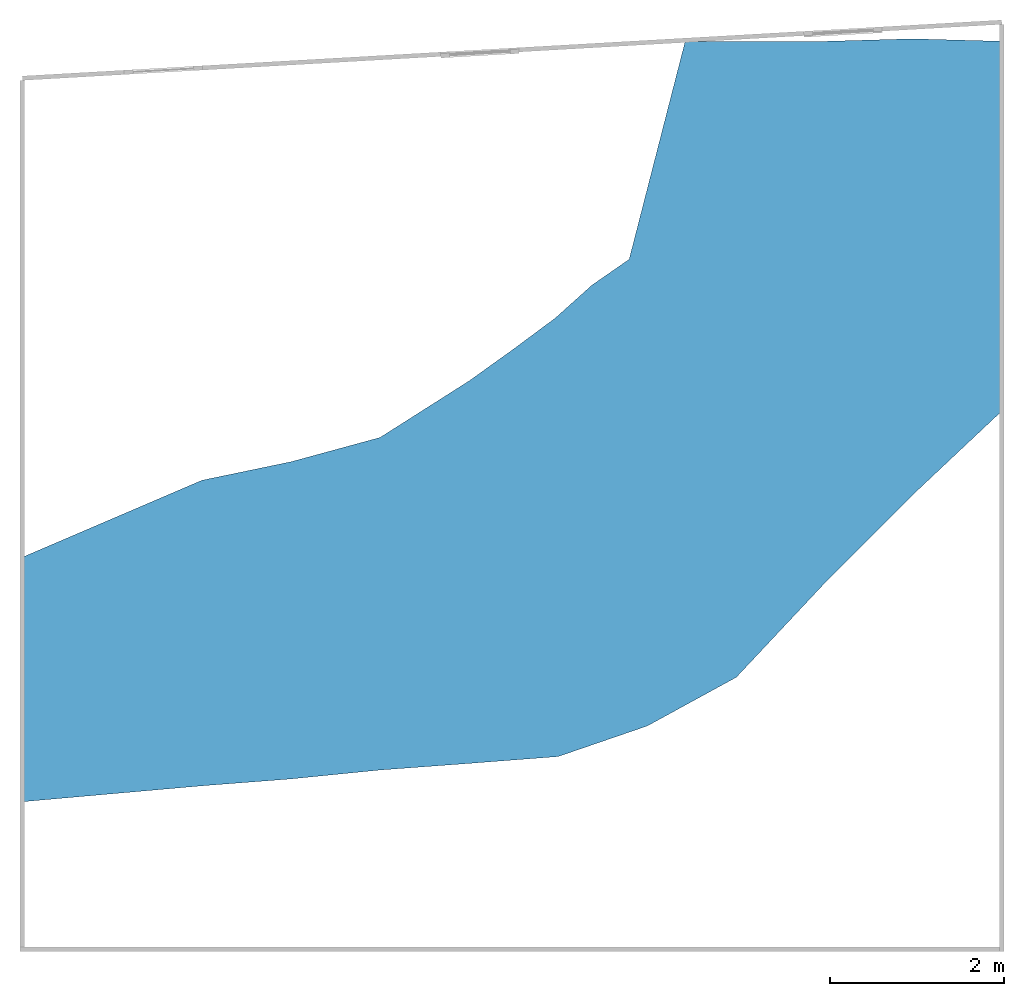
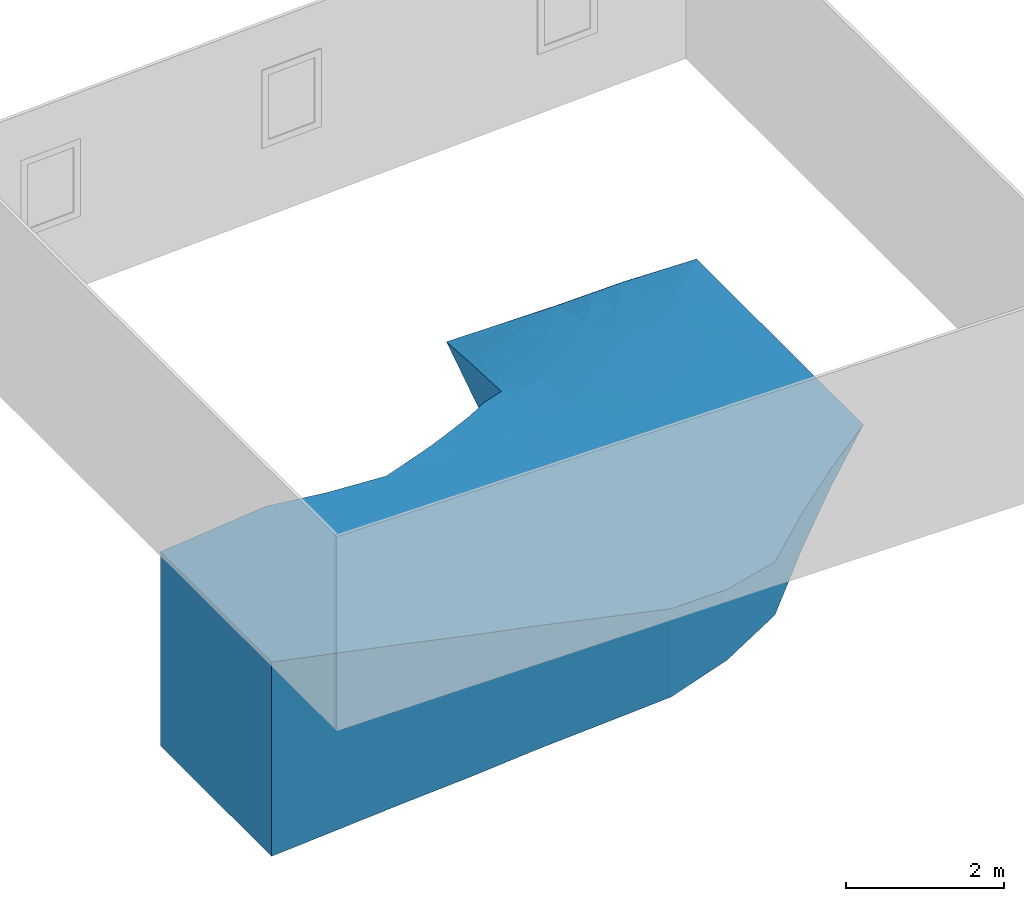
# One storey, part 2 of 3: 1 ramp.
"""IFC4 building model written with IfcOpenShell, lengths in metres."""

from ifc_helpers import new_model, entity, si_unit, converted_unit, frame, origin_with_axes, origin_2d_with_axis, place, context, subcontext, project, spatial, polygons, element, save


model = new_model("IFC4")

# Units and contexts
model_context = context("Model", 3, precision=1e-05, world=origin_with_axes())
plan_context = context("Plan", 2, precision=1e-05, world=origin_2d_with_axis())
body_context = subcontext(model_context, "Body", "Model", "MODEL_VIEW")
ifc_project = project(units=[si_unit("VOLUMEUNIT", "CUBIC_METRE"), si_unit("LENGTHUNIT", "METRE"), converted_unit("PLANEANGLEUNIT", "degree", entity("IfcReal", 0.0174532925199433), si_unit("PLANEANGLEUNIT", "RADIAN"), dimensions=[0, 0, 0, 0, 0, 0, 0]), si_unit("AREAUNIT", "SQUARE_METRE")], contexts=[model_context, plan_context])

# Site, building, storey
site_placement = place(None, origin_with_axes())
site = spatial("IfcSite", under=ifc_project, at=site_placement)
building_placement = place(site_placement, origin_with_axes())
building = spatial("IfcBuilding", under=site, at=building_placement, Name="Building")
storey_placement = place(building_placement, origin_with_axes())
storey = spatial("IfcBuildingStorey", under=building, at=storey_placement, Name="Storey0")

# Ramp
ramp_placement = place(storey_placement, frame((-2.38636875152588, -26.9014205932617, 3.0), z_axis=(0.0, 0.0, 1.0), x_axis=(1.0, 0.0, 0.0)))
element("IfcRamp", 1, at=ramp_placement, inside=storey, Name="Plane", PredefinedType="STRAIGHT_RUN_RAMP", context=body_context, shape_type="Tessellation", body=[
    polygons([(-1.00000011920929, -1.00000011920929, 0.0), (-1.00000011920929, 1.80932641029358, 0.0), (10.238823890686, 7.72010040283203, -3.0), (0.0217113513499498, -0.909389615058899, -0.272727310657501), (1.04342269897461, -0.818777203559875, -0.545454621315002), (2.06513404846191, -0.739626109600067, -0.818181991577148), (3.08684539794922, -0.637556254863739, -1.09090924263), (4.10855674743652, -0.561822950839996, -1.36363649368286), (5.13026809692383, -0.483061134815216, -1.63636386394501), (6.15197992324829, -0.13229013979435, -1.90909111499786), (7.1736912727356, 0.4265256524086, -2.18181848526001), (8.19540214538574, 1.51551151275635, -2.45454573631287), (9.21711349487305, 2.53799510002136, -2.72727298736572), (9.18832874298096, 7.74888467788696, -3.00458192825317), (8.19540119171143, 7.72010040283203, -3.00458192825317), (7.17369079589844, 7.72010135650635, -3.00000023841858), (6.58654451370239, 7.72010040283203, -3.0), (5.09745216369629, 4.54690027236938, -1.69928789138794), (4.10855627059937, 3.82565927505493, -1.3805969953537), (3.08684492111206, 3.17677140235901, -1.09090936183929), (2.06513357162476, 2.8982298374176, -0.818182051181793), (1.04342234134674, 2.68570160865784, -0.545454680919647), (0.0217111129313707, 2.24751305580139, -0.272727340459824), (-1.00000011920929, 0.842850804328918, 0.0), (10.2388248443604, 7.12004566192627, -3.00000023841858), (0.0217112321406603, 1.13569843769073, -0.272727340459824), (1.04342257976532, 1.42854702472687, -0.545454680919647), (2.06513381004333, 1.92072582244873, -0.818181991577148), (3.06936955451965, 2.31345629692078, -1.09094202518463), (3.9922149181366, 2.8869469165802, -1.36587369441986), (5.07592391967773, 3.56458282470703, -1.67543172836304), (6.07935428619385, 4.50835800170898, -2.01254725456238), (7.16741132736206, 5.27234745025635, -2.34002208709717), (8.32406616210938, 6.29180955886841, -2.69019794464111), (9.32558631896973, 6.72331237792969, -2.8524489402771), (5.94412326812744, 5.22002935409546, -2.02513146400452), (7.20553493499756, 6.58756732940674, -2.61047077178955), (6.47213459014893, 6.00016975402832, -2.36925721168518), (-1.00000011920929, -0.0785746648907661, 0.0), (10.2388248443604, 5.74165201187134, -3.00000023841858), (0.0217112917453051, 0.113154426217079, -0.272727340459824), (1.04342257976532, 0.304884940385818, -0.545454680919647), (2.06513381004333, 0.590549886226654, -0.818181991577148), (3.06989908218384, 0.895808279514313, -1.09032964706421), (4.02845764160156, 1.23502886295319, -1.36156272888184), (5.09470367431641, 1.70661246776581, -1.64855790138245), (6.09229803085327, 2.29203009605408, -1.92897129058838), (7.17361640930176, 3.00976157188416, -2.18193054199219), (8.20555305480957, 3.90138292312622, -2.48450517654419), (9.22030258178711, 4.76470804214478, -2.7475733757019), (-1.00000011920929, -0.539287388324738, 0.0), (9.7279691696167, 3.01871919631958, -2.86363673210144), (-0.489144504070282, 2.02841973304749, -0.136363670229912), (-0.489144384860992, -0.954694867134094, -0.136363655328751), (0.532567024230957, -0.864083409309387, -0.409090965986252), (1.55427837371826, -0.779201626777649, -0.681818306446075), (2.57598972320557, -0.688591182231903, -0.954545617103577), (3.59770107269287, -0.599689602851868, -1.22727286815643), (4.61941242218018, -0.522442042827606, -1.50000023841858), (5.64112377166748, -0.307675629854202, -1.77272748947144), (6.66283559799194, 0.147117763757706, -2.04545474052429), (7.68454647064209, 0.971018552780151, -2.31818199157715), (8.70625782012939, 2.02675342559814, -2.59090948104858), (9.7135763168335, 7.73449230194092, -3.00229096412659), (8.69186496734619, 7.73449230194092, -3.00458192825317), (7.68454551696777, 7.72010040283203, -3.00229096412659), (5.51701736450195, 4.92389678955078, -1.86913824081421), (4.61941194534302, 4.19182968139648, -1.54098784923553), (3.59770059585571, 3.50121545791626, -1.2357531785965), (2.57598924636841, 3.03750061988831, -0.954545736312866), (1.5542778968811, 2.79196572303772, -0.68181836605072), (0.532566726207733, 2.46660733222961, -0.409090995788574), (0.0217111725360155, 1.69160580635071, -0.272727340459824), (1.04342246055603, 2.057124376297, -0.545454680919647), (2.06513357162476, 2.40947771072388, -0.818181991577148), (3.08059000968933, 2.81641149520874, -1.09102737903595), (4.00673770904541, 3.41367888450623, -1.36823689937592), (5.07591152191162, 4.12479496002197, -1.68697142601013), (6.52955055236816, 6.70842695236206, -2.60109519958496), (7.18332719802856, 7.13279390335083, -2.79062366485596), (9.72796821594238, 7.21484136581421, -2.91390132904053), (-1.00000011920929, 1.32608866691589, 0.0), (9.20272064208984, 7.22923374176025, -2.91619253158569), (0.0217112619429827, 0.624426424503326, -0.272727340459824), (1.04342257976532, 0.866715967655182, -0.545454680919647), (2.06513381004333, 1.25563788414001, -0.818181991577148), (3.06653690338135, 1.64234089851379, -1.09049355983734), (4.01179122924805, 2.11637783050537, -1.36441612243652), (5.08355093002319, 2.71264362335205, -1.66118252277374), (6.07878303527832, 3.47108030319214, -1.95871615409851), (7.16494846343994, 4.20266771316528, -2.25952100753784), (8.2425651550293, 5.05424499511719, -2.5654308795929), (9.218186378479, 5.7711238861084, -2.77771949768066), (8.80649471282959, 6.38499975204468, -2.75708603858948), (7.71658420562744, 5.65891599655151, -2.51701068878174), (6.6453104019165, 4.81480836868286, -2.1861252784729), (5.56711530685425, 3.97225093841553, -1.83170568943024), (4.54249668121338, 3.15800905227661, -1.52025723457336), (3.53398513793945, 2.58593916893005, -1.2272881269455), (2.57598948478699, 2.18031215667725, -0.954545676708221), (1.55427813529968, 1.67463636398315, -0.68181836605072), (0.532566905021667, 1.2821227312088, -0.409090995788574), (-0.489144444465637, 0.989274621009827, -0.136363670229912), (9.7279691696167, 6.91481399536133, -2.91390156745911), (8.17750930786133, 6.96538877487183, -2.79819011688232), (5.92130422592163, 4.90296125411987, -1.99645256996155), (7.1907844543457, 5.97661972045898, -2.44536972045898), (6.2653341293335, 6.47006511688232, -2.50445795059204), (10.238823890686, 7.42007255554199, -3.0), (8.72216892242432, 7.12264156341553, -2.84850287437439), (6.34618759155273, 5.29341888427734, -2.16697382926941), (6.81265878677368, 6.26584243774414, -2.48552489280701), (-1.00000011920929, 0.382138073444366, 0.0), (10.2388248443604, 4.6205472946167, -3.00000023841858), (0.0217113215476274, -0.39811760187149, -0.272727310657501), (1.04342269897461, -0.25694614648819, -0.545454621315002), (2.06513404846191, -0.0745381116867065, -0.818181991577148), (3.08684539794922, 0.13180735707283, -1.09090924263), (4.05365180969238, 0.326851159334183, -1.36086797714233), (5.13026809692383, 0.627216935157776, -1.64246964454651), (6.0985221862793, 1.06404888629913, -1.91749453544617), (7.17369079589844, 1.7180243730545, -2.18181848526001), (8.19540214538574, 2.70086908340454, -2.45454573631287), (9.21711349487305, 3.68480396270752, -2.72727298736572), (9.7279691696167, 5.2866325378418, -2.86363673210144), (-0.489144414663315, 0.0172898806631565, -0.136363670229912), (0.532566964626312, 0.209019690752029, -0.409090995788574), (1.55427813529968, 0.447717428207397, -0.68181836605072), (2.57598972320557, 0.745860457420349, -0.954545676708221), (3.55022358894348, 1.06322395801544, -1.2253702878952), (4.56401014328003, 1.46664869785309, -1.50562739372253), (5.58766603469849, 1.99894142150879, -1.78723669052124), (6.60937786102295, 2.63495540618896, -2.05385804176331), (7.68820905685425, 3.44627285003662, -2.34057021141052), (8.71804904937744, 4.31587076187134, -2.62195253372192), (7.64552450180054, 7.00597429275513, -2.76856899261475), (6.21197271347046, 5.78530979156494, -2.26269292831421), (9.72796821594238, 4.15267562866211, -2.86363649368286), (-0.489144444465637, 1.50884711742401, -0.136363670229912), (0.532566785812378, 1.87436485290527, -0.409090995788574), (1.55427801609039, 2.23330092430115, -0.68181836605072), (2.57598924636841, 2.60890626907349, -0.954545617103577), (3.54279565811157, 3.10880041122437, -1.22874450683594), (4.56165027618408, 3.72631525993347, -1.52912187576294), (5.52128410339355, 4.48945140838623, -1.84505414962769), (6.73309564590454, 5.58768367767334, -2.29455375671387), (6.33451175689697, 6.31905841827393, -2.45455574989319), (8.51404190063477, 7.40519237518311, -2.8751482963562), (8.74632358551025, 5.3815598487854, -2.68054723739624), (7.69802951812744, 4.62799167633057, -2.414794921875), (6.62396574020386, 3.78940081596375, -2.11379814147949), (5.59095811843872, 3.07251143455505, -1.8106290102005), (4.5409197807312, 2.44791913032532, -1.51072013378143), (3.53394079208374, 1.89164793491364, -1.2255767583847), (2.57598948478699, 1.46308612823486, -0.954545617103577), (1.55427813529968, 1.06117689609528, -0.68181836605072), (0.532566905021667, 0.745571136474609, -0.409090995788574), (-0.489144414663315, 0.503282189369202, -0.136363670229912), (9.72796726226807, 6.10072374343872, -2.88876938819885), (6.1580286026001, 5.27698707580566, -2.11813592910767), (9.89825439453125, 7.18324279785156, -2.94260096549988), (9.54808807373047, 7.39285564422607, -2.9441282749176), (6.85141277313232, 6.95678949356079, -2.71931004524231), (-0.48914435505867, -0.468702495098114, -0.136363655328751), (0.532567024230957, -0.32753187417984, -0.409090995788574), (1.55427837371826, -0.165742114186287, -0.681818306446075), (2.57598972320557, 0.0286346077919006, -0.954545617103577), (3.5702486038208, 0.229329228401184, -1.22588860988617), (4.59195947647095, 0.477034002542496, -1.50166881084442), (5.6143946647644, 0.84563285112381, -1.77998208999634), (6.63610649108887, 1.39103651046753, -2.0496563911438), (7.68454599380493, 2.20944666862488, -2.31818199157715), (8.70625782012939, 3.19283628463745, -2.59090948104858), (8.89218902587891, 6.94684505462646, -2.83502554893494), (7.5039849281311, 7.27487564086914, -2.83901071548462), (7.67692232131958, 6.44254922866821, -2.62311983108521), (-1.0, -1.0, -3.0), (10.2388248443604, 3.49944305419922, -3.00000023841858), (-1.0, 1.80932641029358, -3.0), (0.0217113494873047, -0.909389495849609, -3.0), (1.04342269897461, -0.818777084350586, -3.0), (2.06513404846191, -0.739626169204712, -3.0), (3.08684539794922, -0.637556314468384, -3.0), (4.10855674743652, -0.561822891235352, -3.0), (5.13026809692383, -0.483061075210571, -3.0), (6.15197992324829, -0.132290124893188, -3.0), (7.1736912727356, 0.426525592803955, -3.0), (8.19540214538574, 1.51551151275635, -3.0), (9.21711349487305, 2.53799510002136, -3.0), (9.18832874298096, 7.74888467788696, -3.0), (8.19540119171143, 7.72010040283203, -3.0), (5.09745216369629, 4.54690027236938, -3.0), (4.10855627059937, 3.82565927505493, -3.0), (3.08684492111206, 3.17677140235901, -3.0), (2.06513357162476, 2.8982298374176, -3.0), (1.04342222213745, 2.68570160865784, -3.0), (0.0217113494873047, 2.24751305580139, -3.0), (-1.0, 0.842850804328918, -3.0), (5.94412326812744, 5.22002935409546, -3.0), (-1.0, -0.0785746574401855, -3.0), (-1.0, -0.539287328720093, -3.0), (9.7279691696167, 3.01871919631958, -3.0), (10.2388248443604, 6.43084859848022, -3.0), (-0.489144325256348, 2.02841973304749, -3.0), (-0.489144325256348, -0.954694747924805, -3.0), (0.532567024230957, -0.864083290100098, -3.0), (1.55427837371826, -0.779201507568359, -3.0), (2.57598972320557, -0.688591241836548, -3.0), (3.59770107269287, -0.599689483642578, -3.0), (4.61941242218018, -0.522442102432251, -3.0), (5.64112377166748, -0.30767560005188, -3.0), (6.66283559799194, 0.147117853164673, -3.0), (7.68454647064209, 0.971018552780151, -3.0), (8.70625782012939, 2.02675342559814, -3.0), (9.7135763168335, 7.73449230194092, -3.0), (8.69186496734619, 7.73449230194092, -3.0), (7.68454551696777, 7.72010040283203, -3.0), (6.88011789321899, 7.72010135650635, -3.0), (5.51701736450195, 4.92389678955078, -3.0), (4.61941194534302, 4.19182968139648, -3.0), (3.59770059585571, 3.50121545791626, -3.0), (2.57598924636841, 3.03750061988831, -3.0), (1.5542778968811, 2.79196572303772, -3.0), (0.532566547393799, 2.46660733222961, -3.0), (-1.0, 1.32608866691589, -3.0), (6.2653341293335, 6.47006511688232, -3.0), (-1.0, 0.382138013839722, -3.0)], [[[13, 52, 138, 124]], [[52, 178, 114, 138]], [[138, 114, 40, 125]], [[124, 138, 125, 50]], [[24, 103, 139, 82]], [[103, 26, 73, 139]], [[139, 73, 23, 53]], [[82, 139, 53, 2]], [[26, 102, 140, 73]], [[102, 27, 74, 140]], [[140, 74, 22, 72]], [[73, 140, 72, 23]], [[27, 101, 141, 74]], [[101, 28, 75, 141]], [[141, 75, 21, 71]], [[74, 141, 71, 22]], [[28, 100, 142, 75]], [[100, 29, 76, 142]], [[142, 76, 20, 70]], [[75, 142, 70, 21]], [[29, 99, 143, 76]], [[99, 30, 77, 143]], [[143, 77, 19, 69]], [[76, 143, 69, 20]], [[30, 98, 144, 77]], [[98, 31, 78, 144]], [[144, 78, 18, 68]], [[77, 144, 68, 19]], [[31, 97, 145, 78]], [[97, 32, 106, 145]], [[145, 106, 36, 67]], [[78, 145, 67, 18]], [[32, 96, 146, 111]], [[96, 33, 107, 146]], [[146, 107, 37, 112]], [[111, 146, 112, 38]], [[36, 137, 147, 108]], [[38, 79, 147, 137]], [[17, 108, 147, 79]], [[34, 110, 148, 105]], [[14, 65, 148, 110]], [[15, 105, 148, 65]], [[49, 135, 149, 92]], [[135, 50, 93, 149]], [[149, 93, 35, 94]], [[92, 149, 94, 34]], [[48, 134, 150, 91]], [[134, 49, 92, 150]], [[150, 92, 34, 95]], [[91, 150, 95, 33]], [[47, 133, 151, 90]], [[133, 48, 91, 151]], [[151, 91, 33, 96]], [[90, 151, 96, 32]], [[46, 132, 152, 89]], [[132, 47, 90, 152]], [[152, 90, 32, 97]], [[89, 152, 97, 31]], [[45, 131, 153, 88]], [[131, 46, 89, 153]], [[153, 89, 31, 98]], [[88, 153, 98, 30]], [[44, 130, 154, 87]], [[130, 45, 88, 154]], [[154, 88, 30, 99]], [[87, 154, 99, 29]], [[43, 129, 155, 86]], [[129, 44, 87, 155]], [[155, 87, 29, 100]], [[86, 155, 100, 28]], [[42, 128, 156, 85]], [[128, 43, 86, 156]], [[156, 86, 28, 101]], [[85, 156, 101, 27]], [[41, 127, 157, 84]], [[127, 42, 85, 157]], [[157, 85, 27, 102]], [[84, 157, 102, 26]], [[39, 126, 158, 113]], [[126, 41, 84, 158]], [[158, 84, 26, 103]], [[113, 158, 103, 24]], [[50, 125, 159, 93]], [[125, 40, 203, 159]], [[159, 203, 25, 104]], [[93, 159, 104, 35]], [[36, 106, 160, 137]], [[32, 111, 160, 106]], [[38, 137, 160, 111]], [[3, 81, 161, 109]], [[35, 104, 161, 81]], [[25, 109, 161, 104]], [[14, 83, 162, 64]], [[35, 81, 162, 83]], [[3, 64, 162, 81]], [[38, 112, 163, 79]], [[112, 37, 80, 163]], [[163, 80, 16, 218]], [[79, 163, 218, 17]], [[1, 54, 164, 51]], [[54, 4, 115, 164]], [[164, 115, 41, 126]], [[51, 164, 126, 39]], [[4, 55, 165, 115]], [[55, 5, 116, 165]], [[165, 116, 42, 127]], [[115, 165, 127, 41]], [[5, 56, 166, 116]], [[56, 6, 117, 166]], [[166, 117, 43, 128]], [[116, 166, 128, 42]], [[6, 57, 167, 117]], [[57, 7, 118, 167]], [[167, 118, 44, 129]], [[117, 167, 129, 43]], [[7, 58, 168, 118]], [[58, 8, 119, 168]], [[168, 119, 45, 130]], [[118, 168, 130, 44]], [[8, 59, 169, 119]], [[59, 9, 120, 169]], [[169, 120, 46, 131]], [[119, 169, 131, 45]], [[9, 60, 170, 120]], [[60, 10, 121, 170]], [[170, 121, 47, 132]], [[120, 170, 132, 46]], [[10, 61, 171, 121]], [[61, 11, 122, 171]], [[171, 122, 48, 133]], [[121, 171, 133, 47]], [[11, 62, 172, 122]], [[62, 12, 123, 172]], [[172, 123, 49, 134]], [[122, 172, 134, 48]], [[12, 63, 173, 123]], [[63, 13, 124, 173]], [[173, 124, 50, 135]], [[123, 173, 135, 49]], [[35, 83, 174, 94]], [[14, 110, 174, 83]], [[34, 94, 174, 110]], [[15, 66, 175, 136]], [[16, 80, 175, 66]], [[37, 136, 175, 80]], [[15, 136, 176, 105]], [[136, 37, 107, 176]], [[176, 107, 33, 95]], [[105, 176, 95, 34]], [[72, 22, 196, 224]], [[60, 9, 185, 211]], [[23, 72, 224, 197]], [[10, 60, 211, 186]], [[61, 10, 186, 212]], [[11, 61, 212, 187]], [[113, 24, 198, 227]], [[62, 11, 187, 213]], [[39, 113, 227, 200]], [[12, 62, 213, 188]], [[63, 12, 188, 214]], [[51, 39, 200, 201]], [[13, 63, 214, 189]], [[1, 51, 201, 177]], [[64, 3, 215]], [[52, 13, 189, 202]], [[14, 64, 215, 190]], [[178, 52, 202]], [[65, 14, 190, 216]], [[15, 65, 216, 191]], [[66, 15, 191, 217]], [[53, 23, 197, 204]], [[16, 66, 217]], [[2, 53, 204, 179]], [[54, 1, 177, 205]], [[4, 54, 205, 180]], [[67, 36, 199, 219]], [[55, 4, 180, 206]], [[18, 67, 219, 192]], [[5, 55, 206, 181]], [[68, 18, 192, 220]], [[56, 5, 181, 207]], [[19, 68, 220, 193]], [[6, 56, 207, 182]], [[108, 17, 226]], [[82, 2, 179, 225]], [[69, 19, 193, 221]], [[57, 6, 182, 208]], [[36, 108, 226, 199]], [[24, 82, 225, 198]], [[20, 69, 221, 194]], [[7, 57, 208, 183]], [[70, 20, 194, 222]], [[58, 7, 183, 209]], [[21, 70, 222, 195]], [[8, 58, 209, 184]], [[71, 21, 195, 223]], [[59, 8, 184, 210]], [[22, 71, 223, 196]], [[9, 59, 210, 185]], [[200, 227, 198, 225, 179, 204, 197, 224, 196, 223, 195, 222, 194, 221, 193, 220, 192, 219, 199, 226, 17, 218, 16, 217, 191, 216, 190, 215, 3, 109, 25, 203, 40, 114, 178, 202, 189, 214, 188, 213, 187, 212, 186, 211, 185, 210, 184, 209, 183, 208, 182, 207, 181, 206, 180, 205, 177, 201]]]),
])

save(model, "model.ifc")
